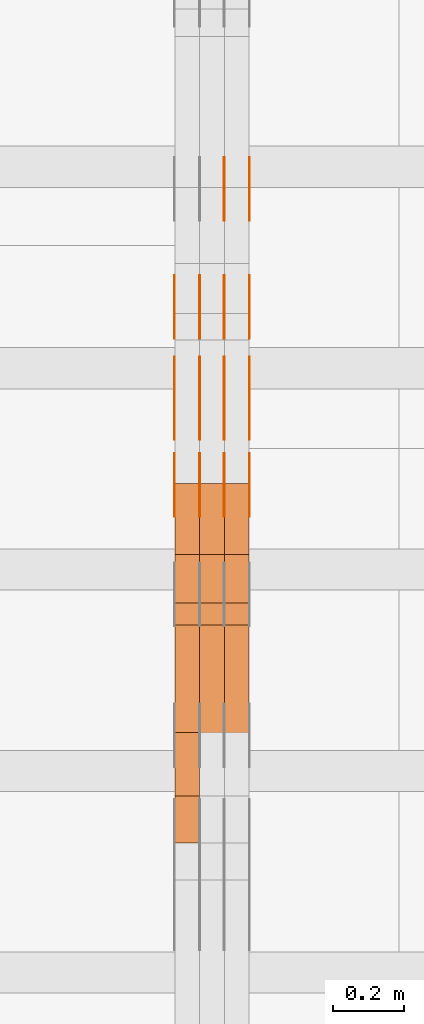
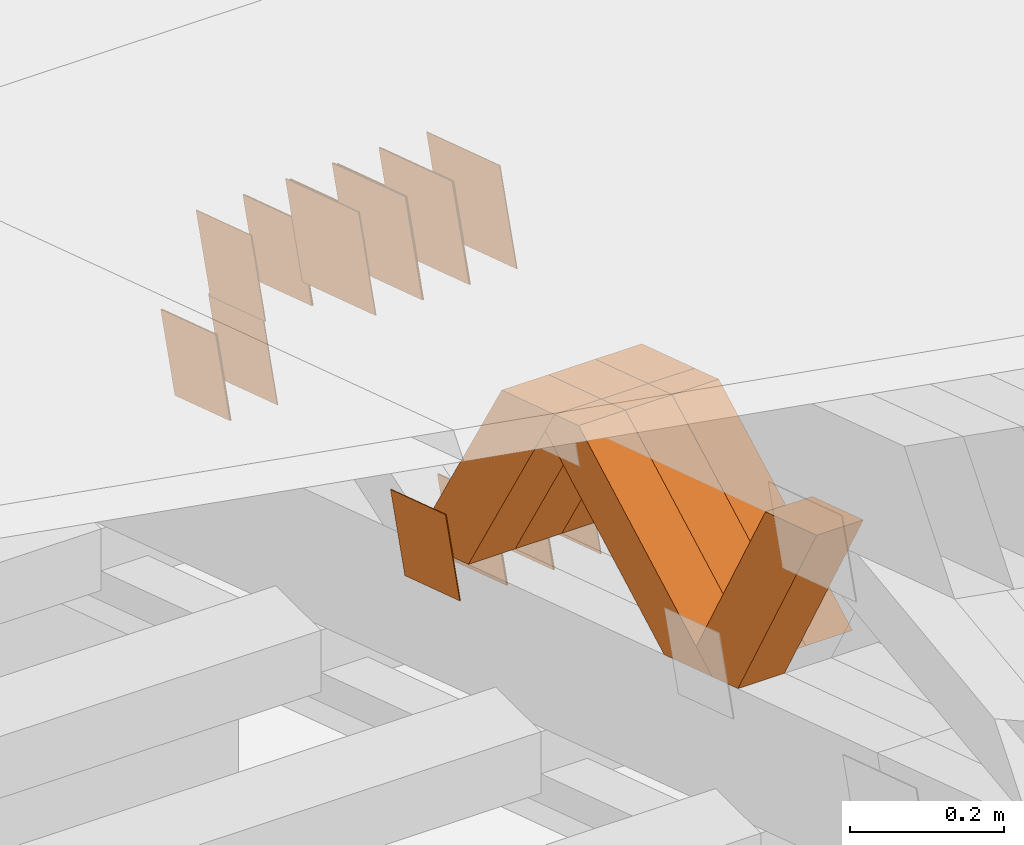
# One storey, part 178 of 385: 28 proxies.
"""IFC2X3 building model written with IfcOpenShell, lengths in millimetres."""

from ifc_helpers import new_model, entity, si_unit, converted_unit, derived_unit, direction, frame, origin, place, context, subcontext, project, spatial, polyline, outline, extrude, source, transform, mapped, material, type_object, type_shapes, element, save


model = new_model("IFC2X3")

# Units and contexts
model_context = context("Model", 3, precision=0.01, world=origin(), true_north=direction((6.12303176911189e-17, 1.0)))
body_context = subcontext(model_context, "Body", "Model", "MODEL_VIEW")
ifc_project = project(units=[si_unit("LENGTHUNIT", "METRE", prefix="MILLI"), si_unit("AREAUNIT", "SQUARE_METRE"), si_unit("VOLUMEUNIT", "CUBIC_METRE"), converted_unit("PLANEANGLEUNIT", "DEGREE", entity("IfcRatioMeasure", 0.0174532925199433), si_unit("PLANEANGLEUNIT", "RADIAN"), dimensions=[0, 0, 0, 0, 0, 0, 0]), si_unit("MASSUNIT", "GRAM", prefix="KILO"), derived_unit("MASSDENSITYUNIT", [(si_unit("MASSUNIT", "GRAM", prefix="KILO"), 1), (si_unit("LENGTHUNIT", "METRE"), -3)]), si_unit("TIMEUNIT", "SECOND"), si_unit("FREQUENCYUNIT", "HERTZ"), si_unit("THERMODYNAMICTEMPERATUREUNIT", "DEGREE_CELSIUS"), derived_unit("THERMALTRANSMITTANCEUNIT", [(si_unit("MASSUNIT", "GRAM", prefix="KILO"), 1), (si_unit("THERMODYNAMICTEMPERATUREUNIT", "KELVIN"), -1), (si_unit("TIMEUNIT", "SECOND"), -3)]), derived_unit("VOLUMETRICFLOWRATEUNIT", [(si_unit("LENGTHUNIT", "METRE"), 3), (si_unit("TIMEUNIT", "SECOND"), -1)]), si_unit("ELECTRICCURRENTUNIT", "AMPERE"), si_unit("ELECTRICVOLTAGEUNIT", "VOLT"), si_unit("POWERUNIT", "WATT"), si_unit("FORCEUNIT", "NEWTON", prefix="KILO"), si_unit("ILLUMINANCEUNIT", "LUX"), si_unit("LUMINOUSFLUXUNIT", "LUMEN"), si_unit("LUMINOUSINTENSITYUNIT", "CANDELA"), derived_unit("USERDEFINED", [(si_unit("MASSUNIT", "GRAM", prefix="KILO"), -1), (si_unit("LENGTHUNIT", "METRE"), -2), (si_unit("TIMEUNIT", "SECOND"), 3), (si_unit("LUMINOUSFLUXUNIT", "LUMEN"), 1)]), derived_unit("LINEARVELOCITYUNIT", [(si_unit("LENGTHUNIT", "METRE"), 1), (si_unit("TIMEUNIT", "SECOND"), -1)]), si_unit("PRESSUREUNIT", "PASCAL"), derived_unit("USERDEFINED", [(si_unit("LENGTHUNIT", "METRE"), -2), (si_unit("MASSUNIT", "GRAM", prefix="KILO"), 1), (si_unit("TIMEUNIT", "SECOND"), -2)])], contexts=[model_context])

# Site, building, storey
site_placement = place(None, origin())
site = spatial("IfcSite", under=ifc_project, at=site_placement, CompositionType="ELEMENT")
building_placement = place(site_placement, origin())
building = spatial("IfcBuilding", under=site, at=building_placement, CompositionType="ELEMENT")
storey_placement = place(building_placement, origin())
storey = spatial("IfcBuildingStorey", under=building, at=storey_placement, Name="Default", CompositionType="ELEMENT", Elevation=0.0)

# Proxies
ifc_material_1 = material(Name="IfcSurfaceStyle #108922")
building_element_proxy_type_1 = type_object("IfcBuildingElementProxyType", PredefinedType="NOTDEFINED", material=ifc_material_1)
shared_shape_1 = source(origin(), body_context, "Body", "SweptSolid", [
    extrude(outline(polyline([(-74.9998605591059, -59.9999264677526), (74.999875428623, -59.9999264677526), (74.9998605591068, 59.9999264677526), (-74.9998754286239, 59.9999264677526), (-74.9998605591059, -59.9999264677526)])), frame((75.0000889884782, 60.0000460315623, 0.0), z_axis=(0.0, 0.0, 1.0), x_axis=(-1.0, 0.0, 0.0)), (0.0, 0.0, 1.0), 1.3),
])
type_shapes(building_element_proxy_type_1, [shared_shape_1])
proxy_1_placement = place(building_placement, frame((6386.29999999999, 20621.9679769682, 2241.76551219004), z_axis=(-1.0, 0.0, 0.0), x_axis=(0.0, -0.951056516295154, 0.309016994374948)))
element("IfcBuildingElementProxy", 1, at=proxy_1_placement, inside=storey, type_object=building_element_proxy_type_1, material=ifc_material_1, context=body_context, shape_type="MappedRepresentation", body=[
    mapped(shared_shape_1, transform((0.0, 0.0, 0.0), scale=1.0)),
])
ifc_material_2 = material(Name="IfcSurfaceStyle #108865")
building_element_proxy_type_2 = type_object("IfcBuildingElementProxyType", PredefinedType="NOTDEFINED", material=ifc_material_2)
shared_shape_2 = source(origin(), body_context, "Body", "SweptSolid", [
    extrude(outline(polyline([(-74.9998605591059, -59.9999264677526), (74.999875428623, -59.9999264677526), (74.9998605591068, 59.9999264677526), (-74.9998754286239, 59.9999264677526), (-74.9998605591059, -59.9999264677526)])), frame((75.0000889884782, 60.0000460315623, 0.0), z_axis=(0.0, 0.0, 1.0), x_axis=(-1.0, 0.0, 0.0)), (0.0, 0.0, 1.0), 1.3),
])
type_shapes(building_element_proxy_type_2, [shared_shape_2])
proxy_2_placement = place(building_placement, frame((6315.0, 20621.9679769682, 2241.76551219004), z_axis=(-1.0, 0.0, 0.0), x_axis=(0.0, -0.951056516295154, 0.309016994374948)))
element("IfcBuildingElementProxy", 2, at=proxy_2_placement, inside=storey, type_object=building_element_proxy_type_2, material=ifc_material_2, context=body_context, shape_type="MappedRepresentation", body=[
    mapped(shared_shape_2, transform((0.0, 0.0, 0.0), scale=1.0)),
])
ifc_material_3 = material(Name="IfcSurfaceStyle #108808")
building_element_proxy_type_3 = type_object("IfcBuildingElementProxyType", PredefinedType="NOTDEFINED", material=ifc_material_3)
shared_shape_3 = source(origin(), body_context, "Body", "SweptSolid", [
    extrude(outline(polyline([(-74.9998605591059, -59.9999264677526), (74.999875428623, -59.9999264677526), (74.9998605591068, 59.9999264677526), (-74.9998754286239, 59.9999264677526), (-74.9998605591059, -59.9999264677526)])), frame((75.0000889884782, 60.0000460315623, 0.0), z_axis=(0.0, 0.0, 1.0), x_axis=(-1.0, 0.0, 0.0)), (0.0, 0.0, 1.0), 1.3),
])
type_shapes(building_element_proxy_type_3, [shared_shape_3])
proxy_3_placement = place(building_placement, frame((6316.29999999999, 20621.9679769682, 2241.76551219004), z_axis=(-1.0, 0.0, 0.0), x_axis=(0.0, -0.951056516295154, 0.309016994374948)))
element("IfcBuildingElementProxy", 3, at=proxy_3_placement, inside=storey, type_object=building_element_proxy_type_3, material=ifc_material_3, context=body_context, shape_type="MappedRepresentation", body=[
    mapped(shared_shape_3, transform((0.0, 0.0, 0.0), scale=1.0)),
])
ifc_material_4 = material(Name="IfcSurfaceStyle #108751")
building_element_proxy_type_4 = type_object("IfcBuildingElementProxyType", PredefinedType="NOTDEFINED", material=ifc_material_4)
shared_shape_4 = source(origin(), body_context, "Body", "SweptSolid", [
    extrude(outline(polyline([(-74.9998605591059, -59.9999264677526), (74.999875428623, -59.9999264677526), (74.9998605591068, 59.9999264677526), (-74.9998754286239, 59.9999264677526), (-74.9998605591059, -59.9999264677526)])), frame((75.0000889884782, 60.0000460315623, 0.0), z_axis=(0.0, 0.0, 1.0), x_axis=(-1.0, 0.0, 0.0)), (0.0, 0.0, 1.0), 1.29999999999999),
])
type_shapes(building_element_proxy_type_4, [shared_shape_4])
proxy_4_placement = place(building_placement, frame((6245.0, 20621.9679769682, 2241.76551219004), z_axis=(-1.0, 0.0, 0.0), x_axis=(0.0, -0.951056516295154, 0.309016994374948)))
element("IfcBuildingElementProxy", 4, at=proxy_4_placement, inside=storey, type_object=building_element_proxy_type_4, material=ifc_material_4, context=body_context, shape_type="MappedRepresentation", body=[
    mapped(shared_shape_4, transform((0.0, 0.0, 0.0), scale=1.0)),
])
ifc_material_5 = material(Name="IfcSurfaceStyle #108694")
building_element_proxy_type_5 = type_object("IfcBuildingElementProxyType", PredefinedType="NOTDEFINED", material=ifc_material_5)
shared_shape_5 = source(origin(), body_context, "Body", "SweptSolid", [
    extrude(outline(polyline([(-74.9998605591059, -59.9999264677526), (74.999875428623, -59.9999264677526), (74.9998605591068, 59.9999264677526), (-74.9998754286239, 59.9999264677526), (-74.9998605591059, -59.9999264677526)])), frame((75.0000889884782, 60.0000460315623, 0.0), z_axis=(0.0, 0.0, 1.0), x_axis=(-1.0, 0.0, 0.0)), (0.0, 0.0, 1.0), 1.29999999999999),
])
type_shapes(building_element_proxy_type_5, [shared_shape_5])
proxy_5_placement = place(building_placement, frame((6246.29999999999, 20621.9679769682, 2241.76551219004), z_axis=(-1.0, 0.0, 0.0), x_axis=(0.0, -0.951056516295154, 0.309016994374948)))
element("IfcBuildingElementProxy", 5, at=proxy_5_placement, inside=storey, type_object=building_element_proxy_type_5, material=ifc_material_5, context=body_context, shape_type="MappedRepresentation", body=[
    mapped(shared_shape_5, transform((0.0, 0.0, 0.0), scale=1.0)),
])
ifc_material_6 = material(Name="IfcSurfaceStyle #108637")
building_element_proxy_type_6 = type_object("IfcBuildingElementProxyType", PredefinedType="NOTDEFINED", material=ifc_material_6)
shared_shape_6 = source(origin(), body_context, "Body", "SweptSolid", [
    extrude(outline(polyline([(-74.9998605591059, -59.9999264677526), (74.999875428623, -59.9999264677526), (74.9998605591068, 59.9999264677526), (-74.9998754286239, 59.9999264677526), (-74.9998605591059, -59.9999264677526)])), frame((75.0000889884782, 60.0000460315623, 0.0), z_axis=(0.0, 0.0, 1.0), x_axis=(-1.0, 0.0, 0.0)), (0.0, 0.0, 1.0), 1.29999999999999),
])
type_shapes(building_element_proxy_type_6, [shared_shape_6])
proxy_6_placement = place(building_placement, frame((6175.0, 20621.9679769682, 2241.76551219004), z_axis=(-1.0, 0.0, 0.0), x_axis=(0.0, -0.951056516295154, 0.309016994374948)))
element("IfcBuildingElementProxy", 6, at=proxy_6_placement, inside=storey, type_object=building_element_proxy_type_6, material=ifc_material_6, context=body_context, shape_type="MappedRepresentation", body=[
    mapped(shared_shape_6, transform((0.0, 0.0, 0.0), scale=1.0)),
])
ifc_material_7 = material(Name="IfcSurfaceStyle #107212")
building_element_proxy_type_7 = type_object("IfcBuildingElementProxyType", PredefinedType="NOTDEFINED", material=ifc_material_7)
shared_shape_7 = source(origin(), body_context, "Body", "SweptSolid", [
    extrude(outline(polyline([(-100.000260677523, -72.0000050220369), (100.000341220114, -72.0000050220369), (99.9997962944585, 72.0000050220369), (-99.9998768370492, 72.0000050220369), (-100.000260677523, -72.0000050220369)])), frame((100.000341220114, 72.0001826453454, 0.0), z_axis=(0.0, 0.0, 1.0), x_axis=(-1.0, 0.0, 0.0)), (0.0, 0.0, 1.0), 1.3),
])
type_shapes(building_element_proxy_type_7, [shared_shape_7])
proxy_7_placement = place(building_placement, frame((6386.29999999999, 20382.8706354426, 2409.35285895246), z_axis=(-1.0, 0.0, 0.0), x_axis=(0.0, -0.951056516295154, 0.309016994374948)))
element("IfcBuildingElementProxy", 7, at=proxy_7_placement, inside=storey, type_object=building_element_proxy_type_7, material=ifc_material_7, context=body_context, shape_type="MappedRepresentation", body=[
    mapped(shared_shape_7, transform((0.0, 0.0, 0.0), scale=1.0)),
])
ifc_material_8 = material(Name="IfcSurfaceStyle #107155")
building_element_proxy_type_8 = type_object("IfcBuildingElementProxyType", PredefinedType="NOTDEFINED", material=ifc_material_8)
shared_shape_8 = source(origin(), body_context, "Body", "SweptSolid", [
    extrude(outline(polyline([(-100.000260677523, -72.0000050220369), (100.000341220114, -72.0000050220369), (99.9997962944585, 72.0000050220369), (-99.9998768370492, 72.0000050220369), (-100.000260677523, -72.0000050220369)])), frame((100.000341220114, 72.0001826453454, 0.0), z_axis=(0.0, 0.0, 1.0), x_axis=(-1.0, 0.0, 0.0)), (0.0, 0.0, 1.0), 1.3),
])
type_shapes(building_element_proxy_type_8, [shared_shape_8])
proxy_8_placement = place(building_placement, frame((6315.0, 20382.8706354426, 2409.35285895246), z_axis=(-1.0, 0.0, 0.0), x_axis=(0.0, -0.951056516295154, 0.309016994374948)))
element("IfcBuildingElementProxy", 8, at=proxy_8_placement, inside=storey, type_object=building_element_proxy_type_8, material=ifc_material_8, context=body_context, shape_type="MappedRepresentation", body=[
    mapped(shared_shape_8, transform((0.0, 0.0, 0.0), scale=1.0)),
])
ifc_material_9 = material(Name="IfcSurfaceStyle #107098")
building_element_proxy_type_9 = type_object("IfcBuildingElementProxyType", PredefinedType="NOTDEFINED", material=ifc_material_9)
shared_shape_9 = source(origin(), body_context, "Body", "SweptSolid", [
    extrude(outline(polyline([(-100.000260677523, -72.0000050220369), (100.000341220114, -72.0000050220369), (99.9997962944585, 72.0000050220369), (-99.9998768370492, 72.0000050220369), (-100.000260677523, -72.0000050220369)])), frame((100.000341220114, 72.0001826453454, 0.0), z_axis=(0.0, 0.0, 1.0), x_axis=(-1.0, 0.0, 0.0)), (0.0, 0.0, 1.0), 1.3),
])
type_shapes(building_element_proxy_type_9, [shared_shape_9])
proxy_9_placement = place(building_placement, frame((6316.29999999999, 20382.8706354426, 2409.35285895246), z_axis=(-1.0, 0.0, 0.0), x_axis=(0.0, -0.951056516295154, 0.309016994374948)))
element("IfcBuildingElementProxy", 9, at=proxy_9_placement, inside=storey, type_object=building_element_proxy_type_9, material=ifc_material_9, context=body_context, shape_type="MappedRepresentation", body=[
    mapped(shared_shape_9, transform((0.0, 0.0, 0.0), scale=1.0)),
])
ifc_material_10 = material(Name="IfcSurfaceStyle #107041")
building_element_proxy_type_10 = type_object("IfcBuildingElementProxyType", PredefinedType="NOTDEFINED", material=ifc_material_10)
shared_shape_10 = source(origin(), body_context, "Body", "SweptSolid", [
    extrude(outline(polyline([(-100.000260677523, -72.0000050220369), (100.000341220114, -72.0000050220369), (99.9997962944585, 72.0000050220369), (-99.9998768370492, 72.0000050220369), (-100.000260677523, -72.0000050220369)])), frame((100.000341220114, 72.0001826453454, 0.0), z_axis=(0.0, 0.0, 1.0), x_axis=(-1.0, 0.0, 0.0)), (0.0, 0.0, 1.0), 1.29999999999998),
])
type_shapes(building_element_proxy_type_10, [shared_shape_10])
proxy_10_placement = place(building_placement, frame((6245.0, 20382.8706354426, 2409.35285895246), z_axis=(-1.0, 0.0, 0.0), x_axis=(0.0, -0.951056516295154, 0.309016994374948)))
element("IfcBuildingElementProxy", 10, at=proxy_10_placement, inside=storey, type_object=building_element_proxy_type_10, material=ifc_material_10, context=body_context, shape_type="MappedRepresentation", body=[
    mapped(shared_shape_10, transform((0.0, 0.0, 0.0), scale=1.0)),
])
ifc_material_11 = material(Name="IfcSurfaceStyle #106984")
building_element_proxy_type_11 = type_object("IfcBuildingElementProxyType", PredefinedType="NOTDEFINED", material=ifc_material_11)
shared_shape_11 = source(origin(), body_context, "Body", "SweptSolid", [
    extrude(outline(polyline([(-100.000260677523, -72.0000050220369), (100.000341220114, -72.0000050220369), (99.9997962944585, 72.0000050220369), (-99.9998768370492, 72.0000050220369), (-100.000260677523, -72.0000050220369)])), frame((100.000341220114, 72.0001826453454, 0.0), z_axis=(0.0, 0.0, 1.0), x_axis=(-1.0, 0.0, 0.0)), (0.0, 0.0, 1.0), 1.29999999999998),
])
type_shapes(building_element_proxy_type_11, [shared_shape_11])
proxy_11_placement = place(building_placement, frame((6246.29999999999, 20382.8706354426, 2409.35285895246), z_axis=(-1.0, 0.0, 0.0), x_axis=(0.0, -0.951056516295154, 0.309016994374948)))
element("IfcBuildingElementProxy", 11, at=proxy_11_placement, inside=storey, type_object=building_element_proxy_type_11, material=ifc_material_11, context=body_context, shape_type="MappedRepresentation", body=[
    mapped(shared_shape_11, transform((0.0, 0.0, 0.0), scale=1.0)),
])
ifc_material_12 = material(Name="IfcSurfaceStyle #106927")
building_element_proxy_type_12 = type_object("IfcBuildingElementProxyType", PredefinedType="NOTDEFINED", material=ifc_material_12)
shared_shape_12 = source(origin(), body_context, "Body", "SweptSolid", [
    extrude(outline(polyline([(-100.000260677523, -72.0000050220369), (100.000341220114, -72.0000050220369), (99.9997962944585, 72.0000050220369), (-99.9998768370492, 72.0000050220369), (-100.000260677523, -72.0000050220369)])), frame((100.000341220114, 72.0001826453454, 0.0), z_axis=(0.0, 0.0, 1.0), x_axis=(-1.0, 0.0, 0.0)), (0.0, 0.0, 1.0), 1.29999999999999),
])
type_shapes(building_element_proxy_type_12, [shared_shape_12])
proxy_12_placement = place(building_placement, frame((6175.0, 20382.8706354426, 2409.35285895246), z_axis=(-1.0, 0.0, 0.0), x_axis=(0.0, -0.951056516295154, 0.309016994374948)))
element("IfcBuildingElementProxy", 12, at=proxy_12_placement, inside=storey, type_object=building_element_proxy_type_12, material=ifc_material_12, context=body_context, shape_type="MappedRepresentation", body=[
    mapped(shared_shape_12, transform((0.0, 0.0, 0.0), scale=1.0)),
])
ifc_material_13 = material(Name="IfcSurfaceStyle #100714")
building_element_proxy_type_13 = type_object("IfcBuildingElementProxyType", PredefinedType="NOTDEFINED", material=ifc_material_13)
shared_shape_13 = source(origin(), body_context, "Body", "SweptSolid", [
    extrude(outline(polyline([(-74.9998605591118, -59.9999264677598), (74.9998754286171, -59.9999264677598), (74.9998605591136, 59.9999264677598), (-74.9998754286189, 59.9999264677598), (-74.9998605591118, -59.9999264677598)])), frame((75.0000347664736, 60.0000016373434, 0.0), z_axis=(0.0, 0.0, 1.0), x_axis=(-1.0, 0.0, 0.0)), (0.0, 0.0, 1.0), 1.3),
])
type_shapes(building_element_proxy_type_13, [shared_shape_13])
proxy_13_placement = place(building_placement, frame((6386.29999999999, 20117.0890328685, 2105.40814929196), z_axis=(-1.0, 0.0, 0.0), x_axis=(0.0, -0.951056516295124, 0.309016994375039)))
element("IfcBuildingElementProxy", 13, at=proxy_13_placement, inside=storey, type_object=building_element_proxy_type_13, material=ifc_material_13, context=body_context, shape_type="MappedRepresentation", body=[
    mapped(shared_shape_13, transform((0.0, 0.0, 0.0), scale=1.0)),
])
ifc_material_14 = material(Name="IfcSurfaceStyle #100657")
building_element_proxy_type_14 = type_object("IfcBuildingElementProxyType", PredefinedType="NOTDEFINED", material=ifc_material_14)
shared_shape_14 = source(origin(), body_context, "Body", "SweptSolid", [
    extrude(outline(polyline([(-74.9998605591118, -59.9999264677598), (74.9998754286171, -59.9999264677598), (74.9998605591136, 59.9999264677598), (-74.9998754286189, 59.9999264677598), (-74.9998605591118, -59.9999264677598)])), frame((75.0000347664736, 60.0000016373434, 0.0), z_axis=(0.0, 0.0, 1.0), x_axis=(-1.0, 0.0, 0.0)), (0.0, 0.0, 1.0), 1.3),
])
type_shapes(building_element_proxy_type_14, [shared_shape_14])
proxy_14_placement = place(building_placement, frame((6315.0, 20117.0890328685, 2105.40814929196), z_axis=(-1.0, 0.0, 0.0), x_axis=(0.0, -0.951056516295124, 0.309016994375039)))
element("IfcBuildingElementProxy", 14, at=proxy_14_placement, inside=storey, type_object=building_element_proxy_type_14, material=ifc_material_14, context=body_context, shape_type="MappedRepresentation", body=[
    mapped(shared_shape_14, transform((0.0, 0.0, 0.0), scale=1.0)),
])
ifc_material_15 = material(Name="IfcSurfaceStyle #100600")
building_element_proxy_type_15 = type_object("IfcBuildingElementProxyType", PredefinedType="NOTDEFINED", material=ifc_material_15)
shared_shape_15 = source(origin(), body_context, "Body", "SweptSolid", [
    extrude(outline(polyline([(-74.9998605591118, -59.9999264677598), (74.9998754286171, -59.9999264677598), (74.9998605591136, 59.9999264677598), (-74.9998754286189, 59.9999264677598), (-74.9998605591118, -59.9999264677598)])), frame((75.0000347664736, 60.0000016373434, 0.0), z_axis=(0.0, 0.0, 1.0), x_axis=(-1.0, 0.0, 0.0)), (0.0, 0.0, 1.0), 1.3),
])
type_shapes(building_element_proxy_type_15, [shared_shape_15])
proxy_15_placement = place(building_placement, frame((6316.29999999999, 20117.0890328685, 2105.40814929196), z_axis=(-1.0, 0.0, 0.0), x_axis=(0.0, -0.951056516295124, 0.309016994375039)))
element("IfcBuildingElementProxy", 15, at=proxy_15_placement, inside=storey, type_object=building_element_proxy_type_15, material=ifc_material_15, context=body_context, shape_type="MappedRepresentation", body=[
    mapped(shared_shape_15, transform((0.0, 0.0, 0.0), scale=1.0)),
])
ifc_material_16 = material(Name="IfcSurfaceStyle #100543")
building_element_proxy_type_16 = type_object("IfcBuildingElementProxyType", PredefinedType="NOTDEFINED", material=ifc_material_16)
shared_shape_16 = source(origin(), body_context, "Body", "SweptSolid", [
    extrude(outline(polyline([(-74.9998605591118, -59.9999264677598), (74.9998754286171, -59.9999264677598), (74.9998605591136, 59.9999264677598), (-74.9998754286189, 59.9999264677598), (-74.9998605591118, -59.9999264677598)])), frame((75.0000347664736, 60.0000016373434, 0.0), z_axis=(0.0, 0.0, 1.0), x_axis=(-1.0, 0.0, 0.0)), (0.0, 0.0, 1.0), 1.29999999999999),
])
type_shapes(building_element_proxy_type_16, [shared_shape_16])
proxy_16_placement = place(building_placement, frame((6245.0, 20117.0890328685, 2105.40814929196), z_axis=(-1.0, 0.0, 0.0), x_axis=(0.0, -0.951056516295124, 0.309016994375039)))
element("IfcBuildingElementProxy", 16, at=proxy_16_placement, inside=storey, type_object=building_element_proxy_type_16, material=ifc_material_16, context=body_context, shape_type="MappedRepresentation", body=[
    mapped(shared_shape_16, transform((0.0, 0.0, 0.0), scale=1.0)),
])
ifc_material_17 = material(Name="IfcSurfaceStyle #100486")
building_element_proxy_type_17 = type_object("IfcBuildingElementProxyType", PredefinedType="NOTDEFINED", material=ifc_material_17)
shared_shape_17 = source(origin(), body_context, "Body", "SweptSolid", [
    extrude(outline(polyline([(-74.9998605591118, -59.9999264677598), (74.9998754286171, -59.9999264677598), (74.9998605591136, 59.9999264677598), (-74.9998754286189, 59.9999264677598), (-74.9998605591118, -59.9999264677598)])), frame((75.0000347664736, 60.0000016373434, 0.0), z_axis=(0.0, 0.0, 1.0), x_axis=(-1.0, 0.0, 0.0)), (0.0, 0.0, 1.0), 1.29999999999999),
])
type_shapes(building_element_proxy_type_17, [shared_shape_17])
proxy_17_placement = place(building_placement, frame((6246.29999999999, 20117.0890328685, 2105.40814929196), z_axis=(-1.0, 0.0, 0.0), x_axis=(0.0, -0.951056516295124, 0.309016994375039)))
element("IfcBuildingElementProxy", 17, at=proxy_17_placement, inside=storey, type_object=building_element_proxy_type_17, material=ifc_material_17, context=body_context, shape_type="MappedRepresentation", body=[
    mapped(shared_shape_17, transform((0.0, 0.0, 0.0), scale=1.0)),
])
ifc_material_18 = material(Name="IfcSurfaceStyle #100429")
building_element_proxy_type_18 = type_object("IfcBuildingElementProxyType", PredefinedType="NOTDEFINED", material=ifc_material_18)
shared_shape_18 = source(origin(), body_context, "Body", "SweptSolid", [
    extrude(outline(polyline([(-74.9998605591118, -59.9999264677598), (74.9998754286171, -59.9999264677598), (74.9998605591136, 59.9999264677598), (-74.9998754286189, 59.9999264677598), (-74.9998605591118, -59.9999264677598)])), frame((75.0000347664736, 60.0000016373434, 0.0), z_axis=(0.0, 0.0, 1.0), x_axis=(-1.0, 0.0, 0.0)), (0.0, 0.0, 1.0), 1.29999999999999),
])
type_shapes(building_element_proxy_type_18, [shared_shape_18])
proxy_18_placement = place(building_placement, frame((6175.0, 20117.0890328685, 2105.40814929196), z_axis=(-1.0, 0.0, 0.0), x_axis=(0.0, -0.951056516295124, 0.309016994375039)))
element("IfcBuildingElementProxy", 18, at=proxy_18_placement, inside=storey, type_object=building_element_proxy_type_18, material=ifc_material_18, context=body_context, shape_type="MappedRepresentation", body=[
    mapped(shared_shape_18, transform((0.0, 0.0, 0.0), scale=1.0)),
])
ifc_material_19 = material(Name="IfcSurfaceStyle #100372")
building_element_proxy_type_19 = type_object("IfcBuildingElementProxyType", PredefinedType="NOTDEFINED", material=ifc_material_19)
shared_shape_19 = source(origin(), body_context, "Body", "SweptSolid", [
    extrude(outline(polyline([(-74.9998794200132, -59.999984515643), (74.9998565677174, -59.999984515643), (74.9998794200123, 59.999984515643), (-74.9998565677165, 59.999984515643), (-74.9998794200132, -59.999984515643)])), frame((75.0002235343086, 60.0000596852268, 0.0), z_axis=(0.0, 0.0, 1.0), x_axis=(-1.0, 0.0, 0.0)), (0.0, 0.0, 1.0), 1.3),
])
type_shapes(building_element_proxy_type_19, [shared_shape_19])
proxy_19_placement = place(building_placement, frame((6386.29999999999, 20956.2317725846, 1832.75404405346), z_axis=(-1.0, 0.0, 0.0), x_axis=(0.0, -0.951056516295124, 0.309016994375039)))
element("IfcBuildingElementProxy", 19, at=proxy_19_placement, inside=storey, type_object=building_element_proxy_type_19, material=ifc_material_19, context=body_context, shape_type="MappedRepresentation", body=[
    mapped(shared_shape_19, transform((0.0, 0.0, 0.0), scale=1.0)),
])
ifc_material_20 = material(Name="IfcSurfaceStyle #100315")
building_element_proxy_type_20 = type_object("IfcBuildingElementProxyType", PredefinedType="NOTDEFINED", material=ifc_material_20)
shared_shape_20 = source(origin(), body_context, "Body", "SweptSolid", [
    extrude(outline(polyline([(-74.9998794200132, -59.999984515643), (74.9998565677174, -59.999984515643), (74.9998794200123, 59.999984515643), (-74.9998565677165, 59.999984515643), (-74.9998794200132, -59.999984515643)])), frame((75.0002235343086, 60.0000596852268, 0.0), z_axis=(0.0, 0.0, 1.0), x_axis=(-1.0, 0.0, 0.0)), (0.0, 0.0, 1.0), 1.3),
])
type_shapes(building_element_proxy_type_20, [shared_shape_20])
proxy_20_placement = place(building_placement, frame((6315.0, 20956.2317725846, 1832.75404405346), z_axis=(-1.0, 0.0, 0.0), x_axis=(0.0, -0.951056516295124, 0.309016994375039)))
element("IfcBuildingElementProxy", 20, at=proxy_20_placement, inside=storey, type_object=building_element_proxy_type_20, material=ifc_material_20, context=body_context, shape_type="MappedRepresentation", body=[
    mapped(shared_shape_20, transform((0.0, 0.0, 0.0), scale=1.0)),
])
ifc_material_21 = material(Name="IfcSurfaceStyle #100258")
building_element_proxy_type_21 = type_object("IfcBuildingElementProxyType", PredefinedType="NOTDEFINED", material=ifc_material_21)
shared_shape_21 = source(origin(), body_context, "Body", "SweptSolid", [
    extrude(outline(polyline([(-74.9998794200132, -59.999984515643), (74.9998565677174, -59.999984515643), (74.9998794200123, 59.999984515643), (-74.9998565677165, 59.999984515643), (-74.9998794200132, -59.999984515643)])), frame((75.0002235343086, 60.0000596852268, 0.0), z_axis=(0.0, 0.0, 1.0), x_axis=(-1.0, 0.0, 0.0)), (0.0, 0.0, 1.0), 1.3),
])
type_shapes(building_element_proxy_type_21, [shared_shape_21])
proxy_21_placement = place(building_placement, frame((6316.29999999999, 20956.2317725846, 1832.75404405346), z_axis=(-1.0, 0.0, 0.0), x_axis=(0.0, -0.951056516295124, 0.309016994375039)))
element("IfcBuildingElementProxy", 21, at=proxy_21_placement, inside=storey, type_object=building_element_proxy_type_21, material=ifc_material_21, context=body_context, shape_type="MappedRepresentation", body=[
    mapped(shared_shape_21, transform((0.0, 0.0, 0.0), scale=1.0)),
])
ifc_material_22 = material(Name="IfcSurfaceStyle #84166")
building_element_proxy_type_22 = type_object("IfcBuildingElementProxyType", Name="T1-W40 84164", PredefinedType="NOTDEFINED", material=ifc_material_22)
shared_shape_22 = source(origin(), body_context, "Body", "SweptSolid", [
    extrude(outline(polyline([(-190.697067347251, -47.4992767218045), (178.704677543904, -47.4992767218045), (178.119540532346, -0.000296092407564622), (126.935785980356, 47.4999913795318), (-293.062936709355, 47.4988581564849), (-190.697067347251, -47.4992767218045)])), frame((178.7049897723, 47.4999913795318, 0.0), z_axis=(0.0, 0.0, 1.0), x_axis=(-1.0, 0.0, 0.0)), (0.0, 0.0, 1.0), 70.0),
])
type_shapes(building_element_proxy_type_22, [shared_shape_22])
proxy_22_placement = place(building_placement, frame((6245.0, 19280.269490882, 2403.36730959494), z_axis=(-1.0, 0.0, 0.0), x_axis=(0.0, -0.48691092455798, 0.873451630913866)))
element("IfcBuildingElementProxy", 22, at=proxy_22_placement, inside=storey, type_object=building_element_proxy_type_22, material=ifc_material_22, Name="T1-W40", context=body_context, shape_type="MappedRepresentation", body=[
    mapped(shared_shape_22, transform((0.0, 0.0, 0.0), scale=1.0)),
])
ifc_material_23 = material(Name="IfcSurfaceStyle #83902")
building_element_proxy_type_23 = type_object("IfcBuildingElementProxyType", Name="T1-W47 83900", PredefinedType="NOTDEFINED", material=ifc_material_23)
shared_shape_23 = source(origin(), body_context, "Body", "SweptSolid", [
    extrude(outline(polyline([(-273.154581805017, -47.5000119135351), (121.157675769026, -47.5000119135351), (166.341960897813, -0.000128144957132403), (168.441931699108, 47.5000759860137), (-182.78698656093, 47.5000759860137), (-273.154581805017, -47.5000119135351)])), frame((168.441931699108, 47.5000759860137, 0.0), z_axis=(0.0, 0.0, 1.0), x_axis=(-1.0, 0.0, 0.0)), (0.0, 0.0, 1.0), 70.0),
])
type_shapes(building_element_proxy_type_23, [shared_shape_23])
proxy_23_placement = place(building_placement, frame((6385.0, 19755.0380859375, 2553.712890625), z_axis=(-1.0, 0.0, 0.0), x_axis=(0.0, -0.879386813332609, -0.476108005117242)))
element("IfcBuildingElementProxy", 23, at=proxy_23_placement, inside=storey, type_object=building_element_proxy_type_23, material=ifc_material_23, Name="T1-W47", context=body_context, shape_type="MappedRepresentation", body=[
    mapped(shared_shape_23, transform((0.0, 0.0, 0.0), scale=1.0)),
])
ifc_material_24 = material(Name="IfcSurfaceStyle #83836")
building_element_proxy_type_24 = type_object("IfcBuildingElementProxyType", Name="T1-W47 83834", PredefinedType="NOTDEFINED", material=ifc_material_24)
shared_shape_24 = source(origin(), body_context, "Body", "SweptSolid", [
    extrude(outline(polyline([(-273.154581805017, -47.5000119135351), (121.157675769026, -47.5000119135351), (166.341960897813, -0.000128144957132403), (168.441931699108, 47.5000759860137), (-182.78698656093, 47.5000759860137), (-273.154581805017, -47.5000119135351)])), frame((168.441931699108, 47.5000759860137, 0.0), z_axis=(0.0, 0.0, 1.0), x_axis=(-1.0, 0.0, 0.0)), (0.0, 0.0, 1.0), 70.0),
])
type_shapes(building_element_proxy_type_24, [shared_shape_24])
proxy_24_placement = place(building_placement, frame((6315.0, 19755.0380859375, 2553.712890625), z_axis=(-1.0, 0.0, 0.0), x_axis=(0.0, -0.879386813332609, -0.476108005117242)))
element("IfcBuildingElementProxy", 24, at=proxy_24_placement, inside=storey, type_object=building_element_proxy_type_24, material=ifc_material_24, Name="T1-W47", context=body_context, shape_type="MappedRepresentation", body=[
    mapped(shared_shape_24, transform((0.0, 0.0, 0.0), scale=1.0)),
])
ifc_material_25 = material(Name="IfcSurfaceStyle #83770")
building_element_proxy_type_25 = type_object("IfcBuildingElementProxyType", Name="T1-W47 83768", PredefinedType="NOTDEFINED", material=ifc_material_25)
shared_shape_25 = source(origin(), body_context, "Body", "SweptSolid", [
    extrude(outline(polyline([(-273.154581805017, -47.5000119135351), (121.157675769026, -47.5000119135351), (166.341960897813, -0.000128144957132403), (168.441931699108, 47.5000759860137), (-182.78698656093, 47.5000759860137), (-273.154581805017, -47.5000119135351)])), frame((168.441931699108, 47.5000759860137, 0.0), z_axis=(0.0, 0.0, 1.0), x_axis=(-1.0, 0.0, 0.0)), (0.0, 0.0, 1.0), 70.0),
])
type_shapes(building_element_proxy_type_25, [shared_shape_25])
proxy_25_placement = place(building_placement, frame((6245.0, 19755.0380859375, 2553.712890625), z_axis=(-1.0, 0.0, 0.0), x_axis=(0.0, -0.879386813332609, -0.476108005117242)))
element("IfcBuildingElementProxy", 25, at=proxy_25_placement, inside=storey, type_object=building_element_proxy_type_25, material=ifc_material_25, Name="T1-W47", context=body_context, shape_type="MappedRepresentation", body=[
    mapped(shared_shape_25, transform((0.0, 0.0, 0.0), scale=1.0)),
])
ifc_material_26 = material(Name="IfcSurfaceStyle #83506")
building_element_proxy_type_26 = type_object("IfcBuildingElementProxyType", Name="T1-W34 83504", PredefinedType="NOTDEFINED", material=ifc_material_26)
shared_shape_26 = source(origin(), body_context, "Body", "SweptSolid", [
    extrude(outline(polyline([(-197.657161937088, -47.499796538607), (193.17680883218, -47.499796538607), (182.92464491562, -1.98968224184526e-05), (128.354123102956, 47.4998064870182), (-306.798414913668, 47.4998064870182), (-197.657161937088, -47.499796538607)])), frame((193.176852028916, 47.4998566383869, 0.0), z_axis=(0.0, 0.0, 1.0), x_axis=(-1.0, 0.0, 0.0)), (0.0, 0.0, 1.0), 70.0),
])
type_shapes(building_element_proxy_type_26, [shared_shape_26])
proxy_26_placement = place(building_placement, frame((6385.0, 19987.8030409043, 2165.75390635484), z_axis=(-1.0, 0.0, 0.0), x_axis=(0.0, -0.514479403471631, 0.857502736674044)))
element("IfcBuildingElementProxy", 26, at=proxy_26_placement, inside=storey, type_object=building_element_proxy_type_26, material=ifc_material_26, Name="T1-W34", context=body_context, shape_type="MappedRepresentation", body=[
    mapped(shared_shape_26, transform((0.0, 0.0, 0.0), scale=1.0)),
])
ifc_material_27 = material(Name="IfcSurfaceStyle #83440")
building_element_proxy_type_27 = type_object("IfcBuildingElementProxyType", Name="T1-W34 83438", PredefinedType="NOTDEFINED", material=ifc_material_27)
shared_shape_27 = source(origin(), body_context, "Body", "SweptSolid", [
    extrude(outline(polyline([(-197.657161937088, -47.499796538607), (193.17680883218, -47.499796538607), (182.92464491562, -1.98968224184526e-05), (128.354123102956, 47.4998064870182), (-306.798414913668, 47.4998064870182), (-197.657161937088, -47.499796538607)])), frame((193.176852028916, 47.4998566383869, 0.0), z_axis=(0.0, 0.0, 1.0), x_axis=(-1.0, 0.0, 0.0)), (0.0, 0.0, 1.0), 70.0),
])
type_shapes(building_element_proxy_type_27, [shared_shape_27])
proxy_27_placement = place(building_placement, frame((6315.0, 19987.8030409043, 2165.75390635484), z_axis=(-1.0, 0.0, 0.0), x_axis=(0.0, -0.514479403471631, 0.857502736674044)))
element("IfcBuildingElementProxy", 27, at=proxy_27_placement, inside=storey, type_object=building_element_proxy_type_27, material=ifc_material_27, Name="T1-W34", context=body_context, shape_type="MappedRepresentation", body=[
    mapped(shared_shape_27, transform((0.0, 0.0, 0.0), scale=1.0)),
])
ifc_material_28 = material(Name="IfcSurfaceStyle #83374")
building_element_proxy_type_28 = type_object("IfcBuildingElementProxyType", Name="T1-W34 83372", PredefinedType="NOTDEFINED", material=ifc_material_28)
shared_shape_28 = source(origin(), body_context, "Body", "SweptSolid", [
    extrude(outline(polyline([(-197.657161937088, -47.499796538607), (193.17680883218, -47.499796538607), (182.92464491562, -1.98968224184526e-05), (128.354123102956, 47.4998064870182), (-306.798414913668, 47.4998064870182), (-197.657161937088, -47.499796538607)])), frame((193.176852028916, 47.4998566383869, 0.0), z_axis=(0.0, 0.0, 1.0), x_axis=(-1.0, 0.0, 0.0)), (0.0, 0.0, 1.0), 70.0),
])
type_shapes(building_element_proxy_type_28, [shared_shape_28])
proxy_28_placement = place(building_placement, frame((6245.0, 19987.8030409043, 2165.75390635484), z_axis=(-1.0, 0.0, 0.0), x_axis=(0.0, -0.514479403471631, 0.857502736674044)))
element("IfcBuildingElementProxy", 28, at=proxy_28_placement, inside=storey, type_object=building_element_proxy_type_28, material=ifc_material_28, Name="T1-W34", context=body_context, shape_type="MappedRepresentation", body=[
    mapped(shared_shape_28, transform((0.0, 0.0, 0.0), scale=1.0)),
])

save(model, "model.ifc")
